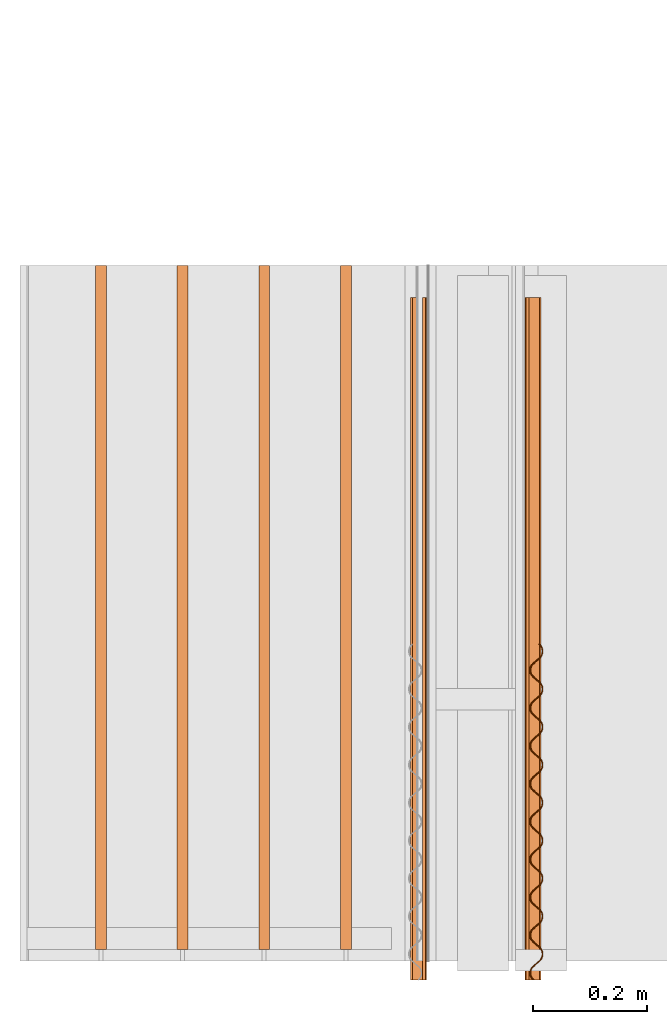
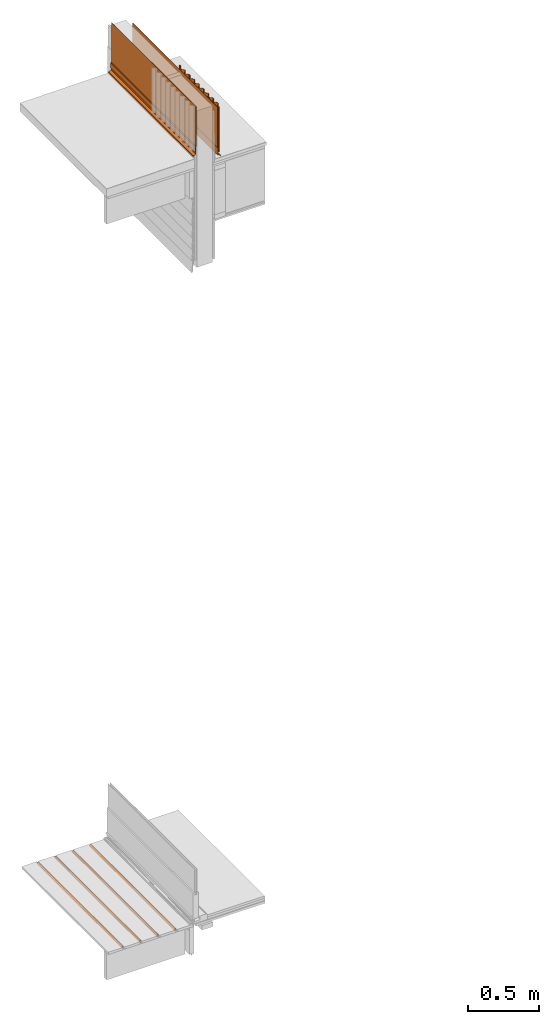
# One storey, part 29 of 33: 9 proxies.
"""IFC4 building model written with IfcOpenShell, lengths in feet."""

from ifc_helpers import new_model, entity, si_unit, converted_unit, derived_unit, direction, frame, origin, place, context, subcontext, project, spatial, polyline, outline, extrude, source, transform, mapped, material, type_object, type_shapes, element, save


model = new_model("IFC4")

# Units and contexts
model_context = context("Model", 3, precision=0.0001, world=origin(), true_north=direction((6.12303176911189e-17, 1.0)))
body_context = subcontext(model_context, "Body", "Model", "MODEL_VIEW")
ifc_project = project(units=[converted_unit("LENGTHUNIT", "FOOT", entity("IfcRatioMeasure", 0.3048), si_unit("LENGTHUNIT", "METRE"), dimensions=[1, 0, 0, 0, 0, 0, 0]), converted_unit("AREAUNIT", "SQUARE FOOT", entity("IfcRatioMeasure", 0.09290304), si_unit("AREAUNIT", "SQUARE_METRE"), dimensions=[2, 0, 0, 0, 0, 0, 0]), converted_unit("VOLUMEUNIT", "CUBIC FOOT", entity("IfcRatioMeasure", 0.028316846592), si_unit("VOLUMEUNIT", "CUBIC_METRE"), dimensions=[3, 0, 0, 0, 0, 0, 0]), converted_unit("PLANEANGLEUNIT", "DEGREE", entity("IfcRatioMeasure", 0.0174532925199433), si_unit("PLANEANGLEUNIT", "RADIAN"), dimensions=[0, 0, 0, 0, 0, 0, 0]), si_unit("MASSUNIT", "GRAM", prefix="KILO"), derived_unit("MASSDENSITYUNIT", [(si_unit("MASSUNIT", "GRAM", prefix="KILO"), 1), (si_unit("LENGTHUNIT", "METRE"), -3)]), derived_unit("MOMENTOFINERTIAUNIT", [(si_unit("LENGTHUNIT", "METRE"), 4)]), si_unit("TIMEUNIT", "SECOND"), si_unit("FREQUENCYUNIT", "HERTZ"), si_unit("THERMODYNAMICTEMPERATUREUNIT", "DEGREE_CELSIUS"), derived_unit("THERMALTRANSMITTANCEUNIT", [(si_unit("MASSUNIT", "GRAM", prefix="KILO"), 1), (si_unit("THERMODYNAMICTEMPERATUREUNIT", "KELVIN"), -1), (si_unit("TIMEUNIT", "SECOND"), -3)]), derived_unit("VOLUMETRICFLOWRATEUNIT", [(si_unit("LENGTHUNIT", "METRE"), 3), (si_unit("TIMEUNIT", "SECOND"), -1)]), si_unit("ELECTRICCURRENTUNIT", "AMPERE"), si_unit("ELECTRICVOLTAGEUNIT", "VOLT"), si_unit("POWERUNIT", "WATT"), si_unit("FORCEUNIT", "NEWTON"), si_unit("ILLUMINANCEUNIT", "LUX"), si_unit("LUMINOUSFLUXUNIT", "LUMEN"), si_unit("LUMINOUSINTENSITYUNIT", "CANDELA"), derived_unit("USERDEFINED", [(si_unit("MASSUNIT", "GRAM", prefix="KILO"), -1), (si_unit("LENGTHUNIT", "METRE"), -2), (si_unit("TIMEUNIT", "SECOND"), 3), (si_unit("LUMINOUSFLUXUNIT", "LUMEN"), 1)]), derived_unit("LINEARVELOCITYUNIT", [(si_unit("LENGTHUNIT", "METRE"), 1), (si_unit("TIMEUNIT", "SECOND"), -1)]), si_unit("PRESSUREUNIT", "PASCAL"), derived_unit("USERDEFINED", [(si_unit("LENGTHUNIT", "METRE"), -2), (si_unit("MASSUNIT", "GRAM", prefix="KILO"), 1), (si_unit("TIMEUNIT", "SECOND"), -2)]), derived_unit("LINEARFORCEUNIT", [(si_unit("MASSUNIT", "GRAM", prefix="KILO"), 1), (si_unit("LENGTHUNIT", "METRE"), 1), (si_unit("TIMEUNIT", "SECOND"), -2), (si_unit("LENGTHUNIT", "METRE"), -1)]), derived_unit("PLANARFORCEUNIT", [(si_unit("MASSUNIT", "GRAM", prefix="KILO"), 1), (si_unit("LENGTHUNIT", "METRE"), 1), (si_unit("TIMEUNIT", "SECOND"), -2), (si_unit("LENGTHUNIT", "METRE"), -2)])], contexts=[model_context])

# Site, building, storey
site_placement = place(None, origin())
site = spatial("IfcSite", under=ifc_project, at=site_placement, CompositionType="ELEMENT")
building_placement = place(site_placement, origin())
building = spatial("IfcBuilding", under=site, at=building_placement, CompositionType="ELEMENT")
storey_placement = place(building_placement, frame((0.0, 0.0, 10.0)))
storey = spatial("IfcBuildingStorey", under=building, at=storey_placement, Name="2ND FLOOR", CompositionType="ELEMENT", Elevation=10.0000000000002)

# Proxies
ifc_material_1 = material(Name="CONCEALED FASTENERS", Category="Materials")
building_element_proxy_type_1 = type_object("IfcBuildingElementProxyType", Name="HIDDEN HIDDEN", PredefinedType="NOTDEFINED", material=ifc_material_1)
shared_shape_1 = source(origin(), body_context, "Body", "SweptSolid", [
    extrude(outline(polyline([(-0.0198466330375755, -0.03125), (-0.00291954970424335, -0.03125), (-0.00291954970424335, -0.0104166666667425), (0.0256857324460658, -0.0104166666667425), (0.0256857324460658, 0.0104166666667425), (-0.00291954970424335, 0.0104166666667425), (-0.00291954970424335, 0.03125), (-0.0198466330375755, 0.03125), (-0.0198466330375755, -0.03125)])), frame((0.03125, 0.0, 0.0256857324460729), z_axis=(0.0, 1.0, 0.0), x_axis=(0.0, 0.0, -1.0)), (0.0, 0.0, 1.0), 3.93229166666686),
])
type_shapes(building_element_proxy_type_1, [shared_shape_1])
proxy_1_placement = place(storey_placement, frame((1458.76105497417, 2.06770833332915, 0.613102542790452)))
element("IfcBuildingElementProxy", 1, at=proxy_1_placement, inside=storey, type_object=building_element_proxy_type_1, material=ifc_material_1, Name="HIDDEN HIDDEN", ObjectType="HIDDEN HIDDEN", PredefinedType="NOTDEFINED", context=body_context, shape_type="MappedRepresentation", body=[
    mapped(shared_shape_1, transform((0.0, 0.0, 0.0), scale=1.0)),
])
building_element_proxy_type_2 = type_object("IfcBuildingElementProxyType", Name="HIDDEN 1:HIDDEN", PredefinedType="NOTDEFINED", material=ifc_material_1)
shared_shape_2 = source(origin(), body_context, "Body", "SweptSolid", [
    extrude(outline(polyline([(-0.0198466330375755, -0.03125), (-0.00291954970424335, -0.03125), (-0.00291954970424335, -0.0104166666667425), (0.0256857324460658, -0.0104166666667425), (0.0256857324460658, 0.0104166666667425), (-0.00291954970424335, 0.0104166666667425), (-0.00291954970424335, 0.03125), (-0.0198466330375755, 0.03125), (-0.0198466330375755, -0.03125)])), frame((0.03125, 0.0, 0.0256857324460729), z_axis=(0.0, 1.0, 0.0), x_axis=(0.0, 0.0, -1.0)), (0.0, 0.0, 1.0), 3.93229166666686),
])
type_shapes(building_element_proxy_type_2, [shared_shape_2])
proxy_2_placement = place(storey_placement, frame((1458.29128867208, 2.06770833332915, 0.613102542790452)))
element("IfcBuildingElementProxy", 2, at=proxy_2_placement, inside=storey, type_object=building_element_proxy_type_2, material=ifc_material_1, Name="HIDDEN 1:HIDDEN", ObjectType="HIDDEN 1:HIDDEN", PredefinedType="NOTDEFINED", context=body_context, shape_type="MappedRepresentation", body=[
    mapped(shared_shape_2, transform((0.0, 0.0, 0.0), scale=1.0)),
])
building_element_proxy_type_3 = type_object("IfcBuildingElementProxyType", Name="HIDDEN 2:HIDDEN", PredefinedType="NOTDEFINED", material=ifc_material_1)
shared_shape_3 = source(origin(), body_context, "Body", "SweptSolid", [
    extrude(outline(polyline([(-0.0198466330375755, -0.03125), (-0.00291954970424335, -0.03125), (-0.00291954970424335, -0.0104166666667425), (0.0256857324460658, -0.0104166666667425), (0.0256857324460658, 0.0104166666667425), (-0.00291954970424335, 0.0104166666667425), (-0.00291954970424335, 0.03125), (-0.0198466330375755, 0.03125), (-0.0198466330375755, -0.03125)])), frame((0.03125, 0.0, 0.0256857324460729), z_axis=(0.0, 1.0, 0.0), x_axis=(0.0, 0.0, -1.0)), (0.0, 0.0, 1.0), 3.93229166666686),
])
type_shapes(building_element_proxy_type_3, [shared_shape_3])
proxy_3_placement = place(storey_placement, frame((1457.82152236998, 2.06770833332915, 0.613102542790452)))
element("IfcBuildingElementProxy", 3, at=proxy_3_placement, inside=storey, type_object=building_element_proxy_type_3, material=ifc_material_1, Name="HIDDEN 2:HIDDEN", ObjectType="HIDDEN 2:HIDDEN", PredefinedType="NOTDEFINED", context=body_context, shape_type="MappedRepresentation", body=[
    mapped(shared_shape_3, transform((0.0, 0.0, 0.0), scale=1.0)),
])
building_element_proxy_type_4 = type_object("IfcBuildingElementProxyType", Name="HIDDEN 3:HIDDEN", PredefinedType="NOTDEFINED", material=ifc_material_1)
shared_shape_4 = source(origin(), body_context, "Body", "SweptSolid", [
    extrude(outline(polyline([(-0.0198466330375755, -0.03125), (-0.00291954970424335, -0.03125), (-0.00291954970424335, -0.0104166666667425), (0.0256857324460658, -0.0104166666667425), (0.0256857324460658, 0.0104166666667425), (-0.00291954970424335, 0.0104166666667425), (-0.00291954970424335, 0.03125), (-0.0198466330375755, 0.03125), (-0.0198466330375755, -0.03125)])), frame((0.03125, 0.0, 0.0256857324460729), z_axis=(0.0, 1.0, 0.0), x_axis=(0.0, 0.0, -1.0)), (0.0, 0.0, 1.0), 3.93229166666686),
])
type_shapes(building_element_proxy_type_4, [shared_shape_4])
proxy_4_placement = place(storey_placement, frame((1457.35175606789, 2.06770833332915, 0.613102542790452)))
element("IfcBuildingElementProxy", 4, at=proxy_4_placement, inside=storey, type_object=building_element_proxy_type_4, material=ifc_material_1, Name="HIDDEN 3:HIDDEN", ObjectType="HIDDEN 3:HIDDEN", PredefinedType="NOTDEFINED", context=body_context, shape_type="MappedRepresentation", body=[
    mapped(shared_shape_4, transform((0.0, 0.0, 0.0), scale=1.0)),
])
ifc_material_2 = material(Name="METAL DRIP FLASHING", Category="Materials")
building_element_proxy_type_5 = type_object("IfcBuildingElementProxyType", Name="Vert", PredefinedType="NOTDEFINED", material=ifc_material_2)
shared_shape_5 = source(origin(), body_context, "Body", "SweptSolid", [
    extrude(outline(polyline([(-0.0410777531858645, 0.0209046738830219), (0.0328120167266977, 0.0209046738830219), (0.0481817936222328, 0.0412540143246793), (0.0332199250296189, 0.0525546641365945), (0.0200358233957077, 0.0350991364387972), (0.0242180791181037, 0.0319402927940025), (0.0342433283164332, 0.0452135700375874), (0.0408407015185286, 0.0402306050630325), (0.0302025161620785, 0.0261458133657394), (-0.0452289372790732, 0.0261457871579454), (-0.0912746326209535, -0.169596554695415), (-0.0861728608037279, -0.170796676388941), (-0.0410777531858645, 0.0209046738830219)])), frame((0.0500142102018799, 0.0, 0.0587651687495807), z_axis=(0.0, 1.0, 0.0), x_axis=(0.973429724736132, 0.0, -0.228985962452154)), (0.0, 0.0, 1.0), 3.92582941211126),
])
type_shapes(building_element_proxy_type_5, [shared_shape_5])
proxy_5_placement = place(storey_placement, frame((1459.82858504986, 1.89104887444255, 22.2158046159017)))
element("IfcBuildingElementProxy", 5, at=proxy_5_placement, inside=storey, type_object=building_element_proxy_type_5, material=ifc_material_2, Name="Vert 1:Vert 62091", ObjectType="Vert 1:Vert 62091", PredefinedType="NOTDEFINED", context=body_context, shape_type="MappedRepresentation", body=[
    mapped(shared_shape_5, transform((0.0, 0.0, 0.0), scale=1.0)),
])
ifc_material_3 = material(Name="DRAINAGE WRAP - ASTM 2273", Category="Materials")
building_element_proxy_type_6 = type_object("IfcBuildingElementProxyType", Name="Vert", PredefinedType="NOTDEFINED", material=ifc_material_3)
shared_shape_6 = source(origin(), body_context, "Body", "SweptSolid", [
    extrude(outline(polyline([(0.177006767423928, 0.158637094718413), (0.20434926764734, 0.158637094718413), (0.303216676176705, 0.242674455770153), (0.299822258634079, 0.246667885141399), (0.203168203366761, 0.164511875790736), (0.175825703143349, 0.164511875790736), (-0.683391646967405, -0.565823426279311), (-0.679997229424779, -0.569816855650558), (0.177006767423928, 0.158637094718413)])), frame((0.0114747374427679, 0.0, 0.388200430957525), z_axis=(0.0, 1.0, 0.0), x_axis=(0.647648705552468, 0.0, -0.761939075120979)), (0.0, 0.0, 1.0), 3.92582941152304),
])
type_shapes(building_element_proxy_type_6, [shared_shape_6])
proxy_6_placement = place(storey_placement, frame((1459.82409754777, 1.89107114296975, 22.3405155406369)))
element("IfcBuildingElementProxy", 6, at=proxy_6_placement, inside=storey, type_object=building_element_proxy_type_6, material=ifc_material_3, Name="Vert 2:Vert 9", ObjectType="Vert 2:Vert 9", PredefinedType="NOTDEFINED", context=body_context, shape_type="MappedRepresentation", body=[
    mapped(shared_shape_6, transform((0.0, 0.0, 0.0), scale=1.0)),
])
ifc_material_4 = material(Category="Materials")
building_element_proxy_type_7 = type_object("IfcBuildingElementProxyType", Name="Generic Models 1:Generic Models 1", PredefinedType="NOTDEFINED", material=ifc_material_4)
shared_shape_7 = source(origin(), body_context, "Body", "SweptSolid", [
    extrude(outline(polyline([(-0.699239933711301, -0.65996763757166), (-0.699869990714554, -0.665152339130581), (-0.686986287249106, -0.665185018880983), (-0.674412986613754, -0.662111777439976), (-0.663082003566337, -0.655969964709285), (-0.653557195415199, -0.647274333100545), (-0.646420828721261, -0.636556460947538), (-0.642232112947132, -0.624326906420992), (-0.641085151407168, -0.611484967118176), (-0.642683557234659, -0.566307231543845), (-0.64146911701024, -0.553539273403542), (-0.637203697055443, -0.541375238023346), (-0.630062712131208, -0.530653140672876), (-0.620542526834638, -0.521961729478832), (-0.609211573377248, -0.515819956484929), (-0.596710407711056, -0.512676990129957), (-0.583884878260488, -0.512627238592395), (-0.53904356102299, -0.518326538461481), (-0.526155187255811, -0.518354976567902), (-0.51358188926503, -0.515281732371377), (-0.502246316642511, -0.509135735091002), (-0.492730754116123, -0.500448544234615), (-0.48559901316594, -0.489734889840033), (-0.481396437924182, -0.477492664402538), (-0.480249474533083, -0.464650727028213), (-0.48185712106337, -0.419481437626086), (-0.480638024950965, -0.406709222823569), (-0.476372600764732, -0.394545191852338), (-0.469236227993447, -0.383827326130224), (-0.459711383945352, -0.375131661749516), (-0.448380472854947, -0.368989914723053), (-0.43588388618542, -0.365851143940008), (-0.423058404701317, -0.365801413027332), (-0.378212460103685, -0.371496497113011), (-0.365319435076967, -0.371520673734854), (-0.352750752412867, -0.368451657859794), (-0.341419807811183, -0.36230987567416), (-0.331904281575551, -0.353622717949258), (-0.324763217252067, -0.342900561973133), (-0.320569883771113, -0.330666781605122), (-0.31941840306792, -0.317820725593888), (-0.321016735574242, -0.272642925209671), (-0.319811557739101, -0.259883390644892), (-0.315536754058342, -0.247710811003286), (-0.3084051338183, -0.236997277754901), (-0.298875666493709, -0.228297392574299), (-0.28755393580895, -0.222164049402731), (-0.275057421089275, -0.219025309556848), (-0.26223185848242, -0.218975521962856), (-0.217381436737139, -0.224666516165604), (-0.204488329265371, -0.224690637484183), (-0.191928883949464, -0.221630035974451), (-0.180597903017918, -0.21548822103911), (-0.171068544312439, -0.206788435021846), (-0.163936758155398, -0.196074756640684), (-0.159738828041853, -0.183836763774687), (-0.158587276794347, -0.170990640059894), (-0.16019022815594, -0.125817081971461), (-0.158980413836785, -0.113053341130207), (-0.154714943089624, -0.10088925276769), (-0.147569416911612, -0.0901630087736321), (-0.138044572469719, -0.0814673440334066), (-0.126722858915021, -0.0753340006720881), (-0.114226287765701, -0.0721952490195832), (-0.101396137699157, -0.0721412746717615), (-0.0565503318061097, -0.0778364701722131), (-0.0436573001676588, -0.0778606536831886), (-0.0310978455084511, -0.0748000707342318), (-0.0197668204867087, -0.0686582134841653), (-0.0102373894810035, -0.059958361460729), (-0.0031011364862827, -0.0492406002375017), (0.00109693696456403, -0.0370024676882882), (0.00224375120118665, -0.0241606573168516), (0.000640867210177285, 0.0210129717820325), (0.00184609715458079, 0.0337725182423471), (0.00611602278015014, 0.0459406512936705), (0.013261646311606, 0.0566670056611648), (0.0227772110938604, 0.0653541985770348), (0.0341036252228938, 0.0714918138703954), (0.0466048074671516, 0.0746347982536667), (0.059439517832679, 0.0746929258772511), (0.104276135228466, 0.068989353365989), (0.117164633720857, 0.0689609971123261), (0.129737939826832, 0.0720342681550797), (0.141068896419979, 0.0781760554971038), (0.150589009697609, 0.0868674009417732), (0.157730160858473, 0.0975896600669336), (0.161928029948588, 0.109827575309032), (0.163074774698756, 0.122669316874668), (0.161467420527324, 0.167838866482043), (0.16268630342035, 0.1806108798271), (0.166947267830723, 0.192770838116934), (0.174088124013422, 0.203492822497045), (0.183612787535979, 0.21218832206776), (0.194943970505738, 0.218330315227111), (0.207435908344466, 0.221464857296585), (0.22026137941633, 0.221514528454561), (0.26510716943745, 0.215819323015248), (0.277995651004383, 0.215790984397703), (0.290569048812005, 0.218864301099026), (0.301899986008523, 0.225006091000517), (0.311424938844499, 0.233701854698643), (0.318561265612209, 0.244419697419845), (0.322754514086349, 0.256653389851684), (0.323901256720799, 0.269495133621801), (0.322298375994109, 0.314668776970356), (0.323512772218926, 0.3274367103525), (0.327778275941351, 0.339600799658157), (0.334914528086139, 0.350318579256307), (0.344444031110786, 0.359018497029119), (0.355775049160371, 0.36516034447223), (0.368267012569351, 0.368294895200534), (0.381092471607895, 0.368344578896691), (0.425938269960049, 0.362649364777088), (0.438826896846594, 0.362621157157903), (0.451400152160205, 0.365694375218336), (0.462731020928127, 0.371836095211785), (0.472251206674754, 0.380527506816706), (0.479383144654356, 0.391241308282609), (0.483580898059592, 0.403479167553695), (0.484732369937562, 0.416325162156617), (0.483129484780847, 0.461498810121067), (0.484339536417763, 0.474262797914376), (0.488613926006308, 0.486434997077938), (0.495750535632645, 0.497153110234221), (0.505275271905486, 0.505848676221987), (0.516601757096221, 0.511986349450039), (0.52909834165003, 0.515125122437567), (0.541923706739073, 0.515174762817313), (0.586769507339234, 0.509479546355383), (0.599658061565747, 0.509451273237121), (0.612226775270569, 0.512520327372926), (0.623562053021987, 0.518666067065451), (0.633086897351366, 0.527361731702958), (0.640209705683432, 0.538067183915542), (0.64441225818099, 0.550309433051472), (0.64556399319414, 0.563155718309646), (0.643960624740562, 0.608328881394957), (0.645170634824345, 0.621092841880734), (0.649440694436733, 0.633261080230682), (0.656581388721151, 0.643982915584508), (0.666101935743881, 0.652674657014855), (0.677427933668419, 0.658811919631903), (0.68992449067617, 0.661950721321196), (0.702754921540564, 0.662004897316768), (0.703515074837365, 0.667037240664986), (0.689325849374541, 0.667098204745596), (0.675578751751424, 0.663631180389416), (0.663058218744004, 0.656945656000794), (0.652590558382738, 0.647389251623651), (0.644804457528648, 0.635535974171531), (0.640112341337743, 0.622168927115316), (0.638865751554526, 0.60801589603299), (0.640338325677464, 0.562994406406495), (0.639277179655244, 0.551450980475737), (0.635447011207646, 0.540498957409988), (0.629166839222745, 0.530681048378898), (0.620591819655607, 0.522852522070505), (0.610247124239597, 0.51749162876542), (0.598977908055908, 0.514659965856912), (0.587404190247759, 0.51466846521336), (0.542688792482075, 0.520211568892986), (0.528494896287867, 0.52026829177756), (0.514747744879985, 0.516801252858904), (0.502231878991013, 0.510119973367793), (0.49175959577518, 0.500559348575954), (0.483968701647222, 0.488701675196411), (0.479281238699725, 0.475338887557922), (0.47803476108013, 0.461185951417489), (0.479511876811726, 0.416168625715195), (0.478450664476915, 0.404625127672173), (0.474688651021776, 0.39359857848355), (0.468339352992513, 0.38385640442303), (0.459755279211986, 0.376019612110442), (0.449415874165951, 0.370661460414186), (0.438156339405377, 0.367838631712201), (0.426577785117029, 0.367842709556506), (0.381857775165629, 0.373381581642208), (0.367659250454346, 0.373434089948814), (0.353921273436683, 0.36997542508919), (0.341400480980585, 0.363289676997622), (0.330928269868077, 0.353729118032196), (0.323142390334011, 0.341875962993477), (0.318449995502238, 0.328508712042036), (0.31720827271078, 0.31436014128397), (0.318680776289579, 0.269338583953151), (0.317619552665843, 0.257795062370793), (0.313857657721483, 0.246768601510616), (0.307501269661486, 0.237033975753514), (0.298923864077918, 0.229203271141941), (0.288656845655144, 0.223761653431713), (0.277325078042959, 0.221008439821462), (0.265746709983651, 0.221012641340508), (0.221031207078605, 0.226555678060862), (0.206828239517821, 0.226604096050158), (0.193094730391212, 0.22314953071816), (0.180569322743208, 0.216459553592591), (0.170097184155955, 0.206899060838777), (0.162311205515229, 0.195045867857176), (0.157618978218558, 0.181678724756826), (0.156377107281444, 0.167529990642835), (0.157849681056572, 0.122508536680068), (0.156788289897736, 0.11096490724662), (0.153026475721263, 0.0999384857865485), (0.146665650350295, 0.0901997629669756), (0.138097491038432, 0.0823774996983922), (0.127825665770644, 0.0769315355031637), (0.116493981752094, 0.074178393650621), (0.104910901375316, 0.074178326700669), (0.0601954118714759, 0.0797213582833361), (0.0459971404085457, 0.0797740704669144), (0.0322636919501986, 0.0763195654779398), (0.0197382148199349, 0.0696295200503915), (0.00926622269520161, 0.0600691610088889), (0.00147989133336842, 0.048215629508985), (-0.00321212097950844, 0.034848694853364), (-0.00445406722122463, 0.0206998979958141), (-0.00298142894199802, -0.0243214930013142), (-0.00403809292885661, -0.0358608672374146), (-0.00780447092946469, -0.0468914294747154), (-0.0141609188209803, -0.0566261085037758), (-0.0227383262103581, -0.0644568147639544), (-0.0330053555670419, -0.0698984387324771), (-0.0443371071336048, -0.0726516602360758), (-0.0559201885682413, -0.0726517260837865), (-0.100635603118596, -0.0671086225659474), (-0.114824716766087, -0.0670475278789243), (-0.128572024956489, -0.0705147035033293), (-0.141092775500862, -0.0772004245073935), (-0.151564950575769, -0.0867609505724513), (-0.159350951794192, -0.0986141906328945), (-0.164043186140861, -0.111981308736514), (-0.165289683867266, -0.126134276879397), (-0.163812481013301, -0.171151516849534), (-0.164878490143379, -0.182699371849228), (-0.168635674885989, -0.193721562035926), (-0.174991954568128, -0.20345608938226), (-0.183564773137829, -0.211282606299746), (-0.193836448506593, -0.216728479569772), (-0.205172828271728, -0.21948592480838), (-0.216746563716109, -0.219477442377654), (-0.261462020241555, -0.213934383378966), (-0.275655867725585, -0.213877605342247), (-0.289403198138669, -0.217344810764451), (-0.301919163598803, -0.224026198821204), (-0.312396069444177, -0.233591043822301), (-0.320177458509648, -0.245440052254387), (-0.324874401297518, -0.258811460516843), (-0.326116185641106, -0.272960108347939), (-0.324638969911351, -0.317977326432185), (-0.325704870232864, -0.329525118296047), (-0.329466762003648, -0.340551582462947), (-0.33581841653637, -0.350281891738789), (-0.344400480871463, -0.358116849537027), (-0.354672148835214, -0.363562730522741), (-0.365994706256015, -0.366307536773385), (-0.377573078365585, -0.366303295732254), (-0.422293211059042, -0.360764507566198), (-0.436487034560609, -0.360707719216815), (-0.450229704854125, -0.364170672385944), (-0.462750348967741, -0.370856292620512), (-0.473217937197551, -0.38041263114556), (-0.481003905259688, -0.392265835149573), (-0.485705466547663, -0.405641468426939), (-0.486942628159586, -0.419785895652284), (-0.485470026698631, -0.464807343160216), (-0.486531380650903, -0.476350976059612), (-0.490293235562666, -0.487377408028179), (-0.496658827701355, -0.497120447783966), (-0.505226951256904, -0.504942678408981), (-0.515494040752843, -0.510384363271732), (-0.526825801753448, -0.513137583770948), (-0.538404208077162, -0.513133377684007), (-0.583119609843079, -0.507590269836611), (-0.597318091347881, -0.50753773594484), (-0.611060763757115, -0.511000686909487), (-0.623576787632176, -0.517682084146348), (-0.634049070876138, -0.527242708963867), (-0.641839696941972, -0.539100167425606), (-0.646531977494555, -0.552467325639467), (-0.647773790763109, -0.566616013935757), (-0.646301165931108, -0.611637415191338), (-0.647362593204385, -0.623181112901392), (-0.651124217045336, -0.634207362012645), (-0.657485265793973, -0.643946239936145), (-0.666053425344928, -0.651768503423007), (-0.676325248942752, -0.657214504660152), (-0.687656890721674, -0.65996763757166), (-0.699239933711301, -0.65996763757166)])), frame((0.0373781839484764, 0.965334648490623, 0.0), z_axis=(0.0, 0.0, -1.0), x_axis=(-0.674229938006036, 0.738521489664571, 0.0)), (0.0, 0.0, -1.0), 1.27535803999433),
])
type_shapes(building_element_proxy_type_7, [shared_shape_7])
proxy_7_placement = place(storey_placement, frame((1459.85021935804, 1.89086121154161, 22.3405155406369)))
element("IfcBuildingElementProxy", 7, at=proxy_7_placement, inside=storey, type_object=building_element_proxy_type_7, material=ifc_material_4, PredefinedType="NOTDEFINED", context=body_context, shape_type="MappedRepresentation", body=[
    mapped(shared_shape_7, transform((0.0, 0.0, 0.0), scale=1.0)),
])
building_element_proxy_type_8 = type_object("IfcBuildingElementProxyType", Name="Vert", PredefinedType="NOTDEFINED", material=ifc_material_2)
shared_shape_8 = source(origin(), body_context, "Body", "SweptSolid", [
    extrude(outline(polyline([(-0.0109430020950114, 0.0447731828451197), (0.18599093715153, 0.0447731828451197), (0.18599093715153, 0.0500142102018799), (-0.0150942946626316, 0.0500142102018799), (-0.0323670641394642, -0.0234130027565698), (-0.0485136141569171, -0.0305433090170482), (-0.0518534745281301, -0.0229802008063871), (-0.0366372305780587, -0.0162607194033626), (-0.0387544650258818, -0.0114662565144954), (-0.0587651687495807, -0.0203029821288965), (-0.051190838193591, -0.0374549999280589), (-0.0278627221738077, -0.0271533155416819), (-0.0109430020950114, 0.0447731828451197)])), frame((0.0374549999278315, 0.0, 0.0587651687495807), z_axis=(0.0, 1.0, 0.0), x_axis=(0.0, 0.0, 1.0)), (0.0, 0.0, 1.0), 3.92582941211126),
])
type_shapes(building_element_proxy_type_8, [shared_shape_8])
proxy_8_placement = place(storey_placement, frame((1459.16510118782, 1.89104887444255, 22.4399385486352)))
element("IfcBuildingElementProxy", 8, at=proxy_8_placement, inside=storey, type_object=building_element_proxy_type_8, material=ifc_material_2, Name="Vert 3:Vert 62091", ObjectType="Vert 3:Vert 62091", PredefinedType="NOTDEFINED", context=body_context, shape_type="MappedRepresentation", body=[
    mapped(shared_shape_8, transform((0.0, 0.0, 0.0), scale=1.0)),
])
building_element_proxy_type_9 = type_object("IfcBuildingElementProxyType", Name="Vert", PredefinedType="NOTDEFINED", material=ifc_material_3)
shared_shape_9 = source(origin(), body_context, "Body", "SweptSolid", [
    extrude(outline(polyline([(-0.237609481708127, 0.00623359743349283), (0.887157609036798, 0.00623359743349283), (0.887157609036798, 0.0114747374427679), (-0.240514377039418, 0.0114747374427679), (-0.261347696371139, -0.00623359743349283), (-0.388200430957525, -0.00623359743349283), (-0.388200430957525, -0.0114747374427679), (-0.258442801039848, -0.0114747374427679), (-0.237609481708127, 0.00623359743349283)])), frame((0.0114747374427679, 0.0, 0.388200430957525), z_axis=(0.0, 1.0, 0.0), x_axis=(0.0, 0.0, 1.0)), (0.0, 0.0, 1.0), 3.92582941152304),
])
type_shapes(building_element_proxy_type_9, [shared_shape_9])
proxy_9_placement = place(storey_placement, frame((1459.23290375164, 1.89107114296975, 22.5607463311749)))
element("IfcBuildingElementProxy", 9, at=proxy_9_placement, inside=storey, type_object=building_element_proxy_type_9, material=ifc_material_3, Name="Vert 4:Vert 9", ObjectType="Vert 4:Vert 9", PredefinedType="NOTDEFINED", context=body_context, shape_type="MappedRepresentation", body=[
    mapped(shared_shape_9, transform((0.0, 0.0, 0.0), scale=1.0)),
])

save(model, "model.ifc")
